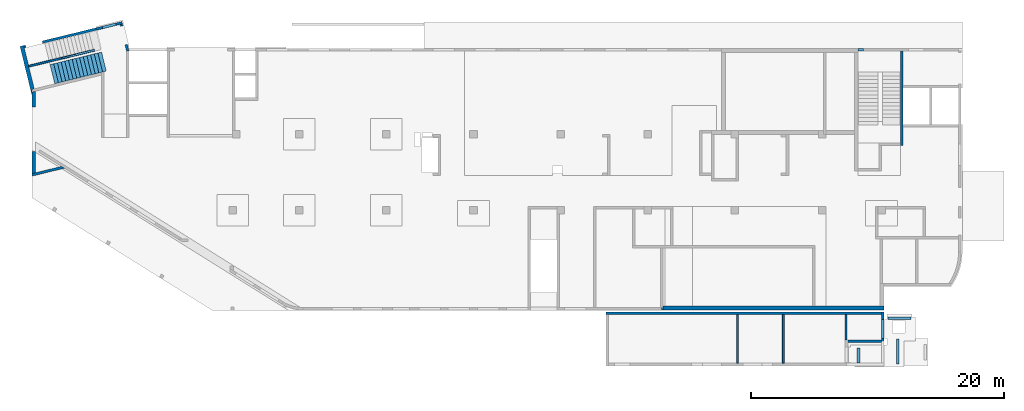
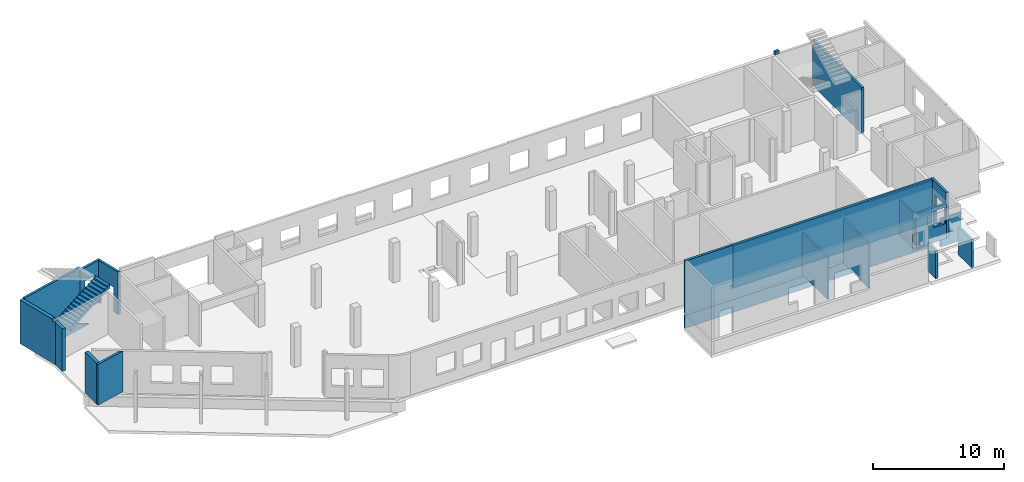
# One storey, part 4 of 8: 20 walls, 1 stair, 7 openings.
"""IFC4 building model written with IfcOpenShell, lengths in millimetres."""

from ifc_helpers import new_model, entity, si_unit, converted_unit, derived_unit, direction, frame, origin, place, context, subcontext, project, spatial, indexed_curve, outline, extrude, polygons, material, type_object, element, save


model = new_model("IFC4")

# Units and contexts
model_context = context("Model", 3, precision=0.01, world=origin(), true_north=direction((6.12303176911189e-17, 1.0)))
plan_context = context("Plan", 3, precision=0.01, world=origin(), true_north=direction((6.12303176911189e-17, 1.0)))
body_context = subcontext(model_context, "Body", "Model", "MODEL_VIEW")
ifc_project = project(units=[si_unit("LENGTHUNIT", "METRE", prefix="MILLI"), si_unit("AREAUNIT", "SQUARE_METRE"), si_unit("VOLUMEUNIT", "CUBIC_METRE"), converted_unit("PLANEANGLEUNIT", "DEGREE", entity("IfcRatioMeasure", 0.0174532925199433), si_unit("PLANEANGLEUNIT", "RADIAN"), dimensions=[0, 0, 0, 0, 0, 0, 0]), si_unit("MASSUNIT", "GRAM", prefix="KILO"), derived_unit("MASSDENSITYUNIT", [(si_unit("MASSUNIT", "GRAM", prefix="KILO"), 1), (si_unit("LENGTHUNIT", "METRE"), -3)]), derived_unit("MOMENTOFINERTIAUNIT", [(si_unit("LENGTHUNIT", "METRE"), 4)]), si_unit("TIMEUNIT", "SECOND"), si_unit("FREQUENCYUNIT", "HERTZ"), si_unit("THERMODYNAMICTEMPERATUREUNIT", "DEGREE_CELSIUS"), derived_unit("THERMALTRANSMITTANCEUNIT", [(si_unit("MASSUNIT", "GRAM", prefix="KILO"), 1), (si_unit("THERMODYNAMICTEMPERATUREUNIT", "KELVIN"), -1), (si_unit("TIMEUNIT", "SECOND"), -3)]), derived_unit("VOLUMETRICFLOWRATEUNIT", [(si_unit("LENGTHUNIT", "METRE"), 3), (si_unit("TIMEUNIT", "SECOND"), -1)]), derived_unit("MASSFLOWRATEUNIT", [(si_unit("MASSUNIT", "GRAM", prefix="KILO"), 1), (si_unit("TIMEUNIT", "SECOND"), -1)]), derived_unit("ROTATIONALFREQUENCYUNIT", [(si_unit("TIMEUNIT", "SECOND"), -1)]), si_unit("ELECTRICCURRENTUNIT", "AMPERE"), si_unit("ELECTRICVOLTAGEUNIT", "VOLT"), si_unit("POWERUNIT", "WATT"), si_unit("FORCEUNIT", "NEWTON", prefix="KILO"), si_unit("ILLUMINANCEUNIT", "LUX"), si_unit("LUMINOUSFLUXUNIT", "LUMEN"), si_unit("LUMINOUSINTENSITYUNIT", "CANDELA"), derived_unit("USERDEFINED", [(si_unit("MASSUNIT", "GRAM", prefix="KILO"), -1), (si_unit("LENGTHUNIT", "METRE"), -2), (si_unit("TIMEUNIT", "SECOND"), 3), (si_unit("LUMINOUSFLUXUNIT", "LUMEN"), 1)]), derived_unit("LINEARVELOCITYUNIT", [(si_unit("LENGTHUNIT", "METRE"), 1), (si_unit("TIMEUNIT", "SECOND"), -1)]), si_unit("PRESSUREUNIT", "PASCAL"), derived_unit("USERDEFINED", [(si_unit("LENGTHUNIT", "METRE"), -2), (si_unit("MASSUNIT", "GRAM", prefix="KILO"), 1), (si_unit("TIMEUNIT", "SECOND"), -2)]), derived_unit("LINEARFORCEUNIT", [(si_unit("MASSUNIT", "GRAM", prefix="KILO"), 1), (si_unit("LENGTHUNIT", "METRE"), 1), (si_unit("TIMEUNIT", "SECOND"), -2), (si_unit("LENGTHUNIT", "METRE"), -1)]), derived_unit("PLANARFORCEUNIT", [(si_unit("MASSUNIT", "GRAM", prefix="KILO"), 1), (si_unit("LENGTHUNIT", "METRE"), 1), (si_unit("TIMEUNIT", "SECOND"), -2), (si_unit("LENGTHUNIT", "METRE"), -2)])], contexts=[model_context, plan_context])

# Site, building, storey
site_placement = place(None, origin())
site = spatial("IfcSite", under=ifc_project, at=site_placement, CompositionType="ELEMENT")
building_placement = place(site_placement, origin())
building = spatial("IfcBuilding", under=site, at=building_placement, CompositionType="ELEMENT")
storey_placement = place(building_placement, origin())
storey = spatial("IfcBuildingStorey", under=building, at=storey_placement, CompositionType="ELEMENT", Elevation=0.0)

# Wall
ifc_material_1 = material()
wall_type_1 = type_object("IfcWallType", PredefinedType="STANDARD")
wall_1_placement = place(storey_placement, frame((68870.0002685547, 20299.9992263562, -250.0), z_axis=(0.0, 0.0, 1.0), x_axis=(0.0, -1.0, 0.0)))
element("IfcWall", 1, at=wall_1_placement, inside=storey, type_object=wall_type_1, material=ifc_material_1, PredefinedType="NOTDEFINED", context=body_context, shape_type="Tessellation", body=[
    polygons([(0.0, -99.9999999999859, 0.0), (100.000000000224, -99.9999999999943, 0.0), (7470.00000000022, -99.9999999999983, 0.0), (7470.00000000022, -99.9999999999983, 100.0), (7470.00000000022, -99.9999999999983, 4050.0), (7470.00000000022, -99.9999999999983, 4300.0), (2520.00000000074, -99.9999999999957, 4300.0), (0.0, -99.9999999999859, 4300.0), (0.0, -99.9999999999859, 4030.0), (2930.00000000025, -99.9999999999945, 4030.0), (2930.00000000025, -99.9999999999945, 3780.0), (0.0, -99.9999999999859, 3780.0), (7470.00000000021, 99.9999999999996, 0.0), (100.00000000022, 100.000000000004, 0.0), (-4.33146851719357e-12, 100.000000000003, 0.0), (-4.33146851719357e-12, 100.000000000003, 3780.0), (2930.00000000024, 99.9999999999947, 3780.0), (2930.00000000024, 99.9999999999947, 4030.0), (-4.33146851719357e-12, 100.000000000003, 4030.0), (-4.33146851719357e-12, 100.000000000003, 4300.0), (2520.00000000074, 100.000000000002, 4300.0), (2730.00000000074, 100.000000000003, 4300.0), (2930.00000000074, 100.000000000003, 4300.0), (7470.00000000021, 99.9999999999996, 4300.0)], [[[1, 2, 3, 4, 5, 6, 7, 8, 9, 10, 11, 12]], [[13, 14, 15, 16, 17, 18, 19, 20, 21, 22, 23, 24]], [[3, 2, 1, 15, 14, 13]], [[8, 7, 6, 24, 23, 22, 21, 20]], [[6, 5, 4, 3, 13, 24]], [[11, 17, 16, 12]], [[18, 10, 9, 19]], [[17, 11, 10, 18]], [[15, 1, 12, 16]], [[8, 20, 19, 9]]], closed=True),
])

# Wall, opening
wall_2_placement = place(storey_placement, frame((7154.27999642213, 22536.2793175299, -150.0), z_axis=(0.0, 0.0, 1.0), x_axis=(-0.971552058141473, -0.236826092990337, 0.0)))
wall_2 = element("IfcWall", 2, at=wall_2_placement, inside=storey, type_object=wall_type_1, material=ifc_material_1, PredefinedType="NOTDEFINED", context=body_context, shape_type="Tessellation", body=[
    polygons([(0.0, -99.9999999999989, 0.0), (2130.93783039304, -100.000000000003, 0.0), (2130.93783039304, -100.000000000003, 3950.0), (2129.99999999999, -100.000000000003, 3950.0), (2.16573425859679e-12, -99.9999999999989, 3950.0), (499.999999999999, -100.000000000319, 2700.0), (1600.0, -100.000000000324, 2700.0), (1600.0, -100.000000000324, 1000.00000000001), (499.999999999999, -100.000000000319, 1000.00000000001), (-1.08286712929839e-12, 99.9999999999989, 0.0), (-1.08286712929839e-12, 99.9999999999989, 3950.0), (199.999999999998, 99.9999999999989, 3950.0), (2130.93783039304, 99.9999999999989, 3950.0), (2130.93783039304, 99.9999999999989, 0.0), (199.999999999999, 99.9999999999989, 0.0), (1600.0, 100.000000000003, 2700.0), (499.999999999999, 99.9999999999989, 2700.0), (499.999999999999, 99.9999999999989, 1000.00000000001), (1600.0, 100.000000000003, 1000.00000000001)], [[[1, 2, 3, 4, 5], [6, 7, 8, 9]], [[10, 11, 12, 13, 14, 15], [16, 17, 18, 19]], [[2, 1, 10, 15, 14]], [[3, 2, 14, 13]], [[5, 4, 3, 13, 12, 11]], [[1, 5, 11, 10]], [[7, 6, 17, 16]], [[7, 16, 19, 8]], [[8, 19, 18, 9]], [[17, 6, 9, 18]]], closed=True),
])
opening_1_placement = place(wall_2_placement, frame((12287.9344363538, 20200.8483740857, 150.0), z_axis=(0.0, 0.0, 1.0), x_axis=(-0.971552058141473, 0.236826092990337, 0.0)))
element("IfcOpeningElement", 3, at=opening_1_placement, cuts=wall_2, PredefinedType="OPENING", context=body_context, shape_type="SweptSolid", body=[
    extrude(outline(indexed_curve([(-550.0, -849.999999999994), (550.0, -849.999999999994), (550.0, 849.999999999994), (-550.0, 849.999999999994), (-550.0, -849.999999999994)], self_intersect=False)), frame((6110.46772607433, 22384.7671257051, 1700.0), z_axis=(0.236826092990338, -0.971552058141473, 0.0), x_axis=(-0.971552058141473, -0.236826092990338, 0.0)), (0.0, 0.0, 1.0), 200.000000000964),
])

wall_3_placement = place(storey_placement, frame((7080.80739990702, 22415.4415024167, -150.0), z_axis=(0.0, 0.0, 1.0), x_axis=(0.236826092990336, -0.971552058141473, 0.0)))
wall_3 = element("IfcWall", 4, at=wall_3_placement, inside=storey, type_object=wall_type_1, material=ifc_material_1, PredefinedType="NOTDEFINED", context=body_context, shape_type="Tessellation", body=[
    polygons([(2180.28371765133, -100.000000000001, 3950.0), (8.66293703438714e-12, -100.0, 3950.0), (8.66293703438714e-12, -100.0, 0.0), (149.999999999996, -100.0, 0.0), (149.999999999996, -100.000000000001, 2279.99999999804), (1649.99999999999, -100.000000000001, 2279.99999999805), (1649.99999999999, -100.000000000001, 0.0), (2180.28371765133, -100.000000000001, 0.0), (4.33146851719357e-12, 99.9999999999989, 3950.0), (1995.90425351864, 99.9999999999984, 3950.0), (2201.76043829436, 99.9999999999978, 3950.0), (2204.30804833156, 99.9999999999978, 3950.0), (2204.30804833156, 99.9999999999978, 0.0), (2201.76043829436, 99.9999999999989, 0.0), (1995.90425351865, 99.9999999999995, 0.0), (1649.99999999999, 99.9999999999989, 0.0), (1649.99999999999, 99.9999999999978, 2279.99999999805), (149.999999999992, 99.9999999999978, 2279.99999999804), (149.999999999996, 99.9999999999989, 0.0), (4.33146851719357e-12, 99.9999999999989, 0.0)], [[[1, 2, 3, 4, 5, 6, 7, 8]], [[9, 10, 11, 12, 13, 14, 15, 16, 17, 18, 19, 20]], [[3, 20, 19, 4]], [[2, 1, 12, 11, 10, 9]], [[3, 2, 9, 20]], [[1, 8, 13, 12]], [[17, 6, 5, 18]], [[18, 5, 4, 19]], [[6, 17, 16, 7]], [[13, 8, 7, 16, 15, 14]]], closed=True),
])
opening_2_placement = place(wall_3_placement, frame((20100.8483740857, -12187.9344363538, 150.0), z_axis=(0.0, 0.0, 1.0), x_axis=(0.236826092990336, 0.971552058141473, 0.0)))
element("IfcOpeningElement", 5, at=opening_2_placement, cuts=wall_3, PredefinedType="OPENING", context=body_context, shape_type="SweptSolid", body=[
    extrude(outline(indexed_curve([(-1139.99999999902, -750.000000000002), (1139.99999999902, -750.000000000002), (1139.99999999902, 749.999999999998), (-1139.99999999902, 749.999999999998), (-1139.99999999902, -750.000000000002)], self_intersect=False)), frame((7099.64047197002, 21493.6794314913, 990.0), z_axis=(0.971552058141473, 0.236826092990336, 0.0), x_axis=(0.0, 0.0, -1.0)), (0.0, 0.0, 1.0), 400.000000001945),
])

# Wall
wall_4_placement = place(storey_placement, frame((-23.6823407443773, 10483.4730084749, 0.0), z_axis=(0.0, 0.0, 1.0), x_axis=(0.971552058141473, 0.236826092990339, 0.0)))
element("IfcWall", 6, at=wall_4_placement, inside=storey, type_object=wall_type_1, material=ifc_material_1, PredefinedType="NOTDEFINED", context=body_context, shape_type="Tessellation", body=[
    polygons([(0.0, -100.000000000001, 0.0), (2669.79789385161, -100.000000000001, 0.0), (2669.79789385161, -99.9999999999989, 3800.0), (0.0, -100.000000000001, 3800.0), (2474.61779994127, 99.9999999999968, 0.0), (357.536393121908, 99.9999999999989, 0.0), (48.7521159583308, 99.9999999999989, 0.0), (48.7521159583302, 99.9999999999989, 3800.0), (2474.61779994127, 99.9999999999989, 3800.0)], [[[1, 2, 3, 4]], [[5, 6, 7, 8, 9]], [[2, 1, 7, 6, 5]], [[2, 5, 9, 3]], [[7, 1, 4, 8]], [[4, 3, 9, 8]]], closed=True),
])

# Wall, opening
wall_5_placement = place(storey_placement, frame((5083.96296153225, 22031.6176367526, -150.0), z_axis=(0.0, 0.0, 1.0), x_axis=(-0.971552058141473, -0.236826092990335, 0.0)))
wall_5 = element("IfcWall", 7, at=wall_5_placement, inside=storey, type_object=wall_type_1, material=ifc_material_1, PredefinedType="NOTDEFINED", context=body_context, shape_type="Tessellation", body=[
    polygons([(5869.05423926975, -100.000000000003, 4200.0), (-1.08286712929839e-12, -100.000000000003, 4200.0), (-1.08286712929839e-12, -100.000000000003, 3950.0), (-1.08286712929839e-12, -100.000000000003, 0.0), (4369.05423926974, -100.000000000003, 0.0), (4369.05423926974, -100.000000000003, 1400.0), (5719.05423926973, -100.000000000003, 1400.0), (5719.05423926973, -100.000000000003, 0.0), (5869.05423926975, -100.000000000003, 0.0), (5869.05423926975, -100.000000000003, 4100.0), (-2.16573425859679e-12, 99.9999999999989, 4200.0), (5869.05423926975, 99.9999999999989, 4200.0), (5869.05423926975, 99.9999999999989, 0.0), (5719.05423926974, 99.9999999999946, 0.0), (5719.05423926974, 100.000000000311, 1400.0), (4369.05423926974, 100.000000000311, 1400.0), (4369.05423926974, 99.9999999999946, 0.0), (-2.16573425859679e-12, 99.9999999999989, 0.0), (-2.16573425859679e-12, 99.9999999999989, 3950.0)], [[[1, 2, 3, 4, 5, 6, 7, 8, 9, 10]], [[11, 12, 13, 14, 15, 16, 17, 18, 19]], [[4, 18, 17, 5]], [[2, 1, 12, 11]], [[4, 3, 2, 11, 19, 18]], [[15, 7, 6, 16]], [[16, 6, 5, 17]], [[7, 15, 14, 8]], [[1, 10, 9, 13, 12]], [[9, 8, 14, 13]]], closed=True),
])
opening_3_placement = place(wall_5_placement, origin())
element("IfcOpeningElement", 8, at=opening_3_placement, cuts=wall_5, PredefinedType="OPENING", context=body_context, shape_type="SweptSolid", body=[
    extrude(outline(indexed_curve([(-1089.99999999999, -675.0), (1089.99999999999, -675.0), (1089.99999999999, 675.0), (-1089.99999999999, 675.0), (-1089.99999999999, -675.0)], self_intersect=False)), frame((5044.05423926974, -200.0, 310.0), z_axis=(0.0, 1.0, 0.0), x_axis=(0.0, 0.0, -1.0)), (0.0, 0.0, 1.0), 300.000000000971),
])

# Walls
wall_6_placement = place(storey_placement, frame((65430.0002685547, 20399.9998657227, 3750.0)))
element("IfcWall", 9, at=wall_6_placement, inside=storey, type_object=wall_type_1, material=ifc_material_1, PredefinedType="NOTDEFINED", context=body_context, shape_type="SweptSolid", body=[
    extrude(outline(indexed_curve([(400.000000000048, 99.9999999999989), (0.0, 99.9999999999989), (0.0, -99.9999999999989), (400.000000000048, -99.9999999999989), (400.000000000048, 99.9999999999989)], self_intersect=False)), origin(), (0.0, 0.0, 1.0), 299.999999999999),
])
wall_7_placement = place(storey_placement, frame((45470.0036168839, -470.000875342555, -2100.0)))
element("IfcWall", 10, at=wall_7_placement, inside=storey, type_object=wall_type_1, material=ifc_material_1, PredefinedType="NOTDEFINED", context=body_context, shape_type="Tessellation", body=[
    polygons([(0.0, -100.0, 0.0), (199.999999999998, -100.0, 0.0), (21799.9966516707, -100.0, 0.0), (21799.9966516707, -100.0, 6280.0), (199.999999999998, -100.0, 6280.0), (0.0, -100.0, 6280.0), (0.0, -100.0, 1400.0), (199.999999999998, -100.0, 1400.0), (10325.0000000001, -100.0, 1400.0), (10475.0000000001, -100.0, 1400.0), (13955.0000000001, -100.0, 1400.0), (13955.0000000001, -100.0, 1200.0), (199.999999999998, -100.0, 1200.0), (0.0, -100.0, 1200.0), (21799.9966516707, 100.0, 0.0), (0.0, 100.0, 0.0), (0.0, 100.0, 1200.0), (13955.0000000001, 99.9999999999986, 1200.0), (13955.0000000001, 99.9999999999986, 1400.0), (0.0, 100.0, 1400.0), (0.0, 100.0, 6280.0), (21799.9966516707, 100.0, 6280.0), (21799.9966516707, 100.0, 2100.0)], [[[1, 2, 3, 4, 5, 6, 7, 8, 9, 10, 11, 12, 13, 14]], [[15, 16, 17, 18, 19, 20, 21, 22, 23]], [[3, 2, 1, 16, 15]], [[6, 5, 4, 22, 21]], [[6, 21, 20, 7]], [[4, 3, 15, 23, 22]], [[12, 18, 17, 14, 13]], [[19, 11, 10, 9, 8, 7, 20]], [[18, 12, 11, 19]], [[16, 1, 14, 17]]], closed=True),
])

# Wall, opening
wall_8_placement = place(storey_placement, frame((67370.0002685546, -370.000875342555, 0.0), z_axis=(0.0, 0.0, 1.0), x_axis=(0.0, -1.0, 0.0)))
wall_8 = element("IfcWall", 11, at=wall_8_placement, inside=storey, type_object=wall_type_1, material=ifc_material_1, PredefinedType="NOTDEFINED", context=body_context, shape_type="Tessellation", body=[
    polygons([(0.0, -100.000000000004, 0.0), (2199.99992981406, -99.9999999999998, 0.0), (2399.99992981406, -99.9999999999916, 0.0), (2399.99992981406, -99.9999999999916, 3230.0), (2299.99992981406, -99.9999999999914, 3230.0), (2299.99992981406, -99.9999999999914, 4180.0), (200.0, -99.9999999999958, 4180.0), (0.0, -100.000000000004, 4180.0), (600.000055868205, -100.000000000005, 2929.99999999804), (2100.00005586821, -99.999999999991, 2929.99999999804), (2100.00005586821, -99.999999999991, 530.0), (600.000055868206, -100.000000000005, 530.0), (2399.99992981406, 100.000000000006, 0.0), (4.06075173486897e-13, 100.000000000002, 0.0), (4.06075173486897e-13, 100.000000000002, 4180.0), (2299.99992981406, 100.000000000006, 4180.0), (2299.99992981406, 100.000000000006, 3230.0), (2399.99992981406, 100.000000000006, 3230.0), (2100.00005586821, 99.9999999999982, 2929.99999999804), (600.000055868206, 100.000000000001, 2929.99999999804), (600.000055868206, 100.000000000001, 530.0), (2100.00005586821, 99.9999999999982, 530.0)], [[[1, 2, 3, 4, 5, 6, 7, 8], [9, 10, 11, 12]], [[13, 14, 15, 16, 17, 18], [19, 20, 21, 22]], [[3, 2, 1, 14, 13]], [[8, 7, 6, 16, 15]], [[1, 8, 15, 14]], [[16, 6, 5, 17]], [[17, 5, 4, 18]], [[3, 13, 18, 4]], [[9, 20, 19, 10]], [[10, 19, 22, 11]], [[11, 22, 21, 12]], [[20, 9, 12, 21]]], closed=True),
])
opening_4_placement = place(wall_8_placement, frame((-370.000875342555, -67370.0002685546, 0.0), z_axis=(0.0, 0.0, 1.0), x_axis=(0.0, 1.0, 0.0)))
element("IfcOpeningElement", 12, at=opening_4_placement, cuts=wall_8, PredefinedType="OPENING", context=body_context, shape_type="SweptSolid", body=[
    extrude(outline(indexed_curve([(-750.0, -1199.99999999902), (750.0, -1199.99999999902), (750.0, 1199.99999999902), (-750.0, 1199.99999999902), (-750.0, -1199.99999999902)], self_intersect=False)), frame((67170.0002685527, -1720.00093121076, 1730.0), z_axis=(1.0, 0.0, 0.0), x_axis=(0.0, -1.0, 0.0)), (0.0, 0.0, 1.0), 400.000000001936),
])

wall_9_placement = place(storey_placement, frame((64600.003616884, -2670.00080515661, 0.0)))
wall_9 = element("IfcWall", 13, at=wall_9_placement, inside=storey, type_object=wall_type_1, material=ifc_material_1, PredefinedType="NOTDEFINED", context=body_context, shape_type="Tessellation", body=[
    polygons([(2.20736734168918e-13, -100.0, 0.0), (2669.99665167067, -100.000000000001, 0.0), (2669.99665167067, -100.000000000001, 3230.0), (2.20736734168918e-13, -100.0, 3230.0), (2569.99665167068, -100.0, 2930.0), (2569.99665167068, -100.0, 1400.0), (1519.99665167067, -100.0, 1400.0), (1519.99665167067, -100.0, 2930.0), (-4.20683568093687e-13, 100.0, 0.0), (-4.20683568093687e-13, 100.0, 330.0), (-4.20683568093687e-13, 100.0, 530.0), (-4.20683568093687e-13, 100.0, 3230.0), (2669.99665167065, 99.9999999999995, 3230.0), (2669.99665167065, 99.9999999999995, 0.0), (2569.99665167068, 100.0, 2930.0), (1519.99665167067, 100.0, 2930.0), (1519.99665167067, 100.0, 1400.0), (2569.99665167068, 100.0, 1400.0), (2669.99665167067, -1.62430069394759e-12, 3230.0)], [[[1, 2, 3, 4], [5, 6, 7, 8]], [[9, 10, 11, 12, 13, 14], [15, 16, 17, 18]], [[1, 4, 12, 11, 10, 9]], [[3, 2, 14, 13, 19]], [[4, 3, 19, 13, 12]], [[2, 1, 9, 14]], [[6, 5, 15, 18]], [[7, 6, 18, 17]], [[8, 7, 17, 16]], [[5, 8, 16, 15]]], closed=True),
])
opening_5_placement = place(wall_9_placement, origin())
element("IfcOpeningElement", 14, at=opening_5_placement, cuts=wall_9, PredefinedType="OPENING", context=body_context, shape_type="SweptSolid", body=[
    extrude(outline(indexed_curve([(-525.000000000002, -765.0), (525.000000000002, -765.0), (525.000000000002, 765.0), (-525.000000000002, 765.0), (-525.000000000002, -765.0)], self_intersect=False)), frame((2044.99665167068, 100.0, 2165.0), z_axis=(0.0, -1.0, 0.0), x_axis=(-1.0, 0.0, 0.0)), (0.0, 0.0, 1.0), 200.0),
])

# Walls
wall_10_placement = place(storey_placement, frame((65450.0036200273, -4420.00087534259, -2100.0), z_axis=(0.0, 0.0, 1.0), x_axis=(0.0, 1.0, 0.0)))
element("IfcWall", 15, at=wall_10_placement, inside=storey, type_object=wall_type_1, material=ifc_material_1, PredefinedType="NOTDEFINED", context=body_context, shape_type="Tessellation", body=[
    polygons([(0.0, -99.9999999999946, 0.0), (1225.00005833431, -99.9999999999946, 0.0), (1225.00005833431, -99.9999999999946, 2590.0), (0.0, -99.9999999999946, 2590.0), (5.41433564649196e-13, 99.9999999999946, 0.0), (5.41433564649196e-13, 99.9999999999946, 2590.0), (1225.00005833431, 99.9999999999946, 2590.0), (1225.00005833431, 99.9999999999946, 0.0)], [[[1, 2, 3, 4]], [[5, 6, 7, 8]], [[2, 1, 5, 8]], [[3, 2, 8, 7]], [[1, 4, 6, 5]], [[4, 3, 7, 6]]], closed=True),
])
wall_11_placement = place(storey_placement, frame((68545.0077758905, -4495.00080359939, -2100.0), z_axis=(0.0, 0.0, 1.0), x_axis=(0.0, 1.0, 0.0)))
element("IfcWall", 16, at=wall_11_placement, inside=storey, type_object=wall_type_1, material=ifc_material_1, PredefinedType="NOTDEFINED", context=body_context, shape_type="Tessellation", body=[
    polygons([(0.0, -99.9999999999946, 0.0), (1999.9999865911, -99.9999999999946, 0.0), (1999.9999865911, -99.9999999999946, 2590.0), (0.0, -99.9999999999946, 2590.0), (0.0, 99.9999999999946, 0.0), (0.0, 99.9999999999946, 2590.0), (1999.9999865911, 99.9999999999946, 2590.0), (1999.9999865911, 99.9999999999946, 0.0)], [[[1, 2, 3, 4]], [[5, 6, 7, 8]], [[2, 1, 5, 8]], [[3, 2, 8, 7]], [[1, 4, 6, 5]], [[4, 3, 7, 6]]], closed=True),
])
wall_12_placement = place(storey_placement, frame((67795.0036168839, -855.000773644068, -2100.0)))
element("IfcWall", 17, at=wall_12_placement, inside=storey, type_object=wall_type_1, material=ifc_material_1, PredefinedType="NOTDEFINED", context=body_context, shape_type="Tessellation", body=[
    polygons([(3.08805379778116e-12, -100.0, 0.0), (1800.00000000001, -100.0, 0.0), (1800.00000000001, -100.0, 2590.0), (3.08805379778116e-12, -100.0, 2590.0), (2.44134148445018e-12, 100.0, 0.0), (2.44134151673763e-12, 99.9999900148955, 2590.0), (1800.00000000001, 100.0, 2590.0), (1800.00000000001, 100.0, 0.0)], [[[1, 2, 3, 4]], [[5, 6, 7, 8]], [[2, 1, 5, 8]], [[3, 2, 8, 7]], [[1, 4, 6, 5]], [[4, 3, 7, 6]]], closed=True),
])
wall_type_2 = type_object("IfcWallType", PredefinedType="STANDARD")
wall_13_placement = place(storey_placement, frame((49870.0002685546, -50.0007736438373, -150.0)))
element("IfcWall", 18, at=wall_13_placement, inside=storey, type_object=wall_type_2, material=ifc_material_1, PredefinedType="NOTDEFINED", context=body_context, shape_type="Tessellation", body=[
    polygons([(6.46066962494362e-13, -150.0, 0.0), (17600.0, -150.0, 0.0), (17600.0, -150.0, 3900.0), (11950.0, -149.999999999981, 3900.0), (11950.0, -150.0, 3950.0), (99.9999999999952, -150.0, 3950.0), (99.9999999999952, -150.0, 150.0), (6.46066962494362e-13, -150.0, 150.0), (17600.0, 150.0, 0.0), (17300.0, 150.0, 0.0), (12150.0, 150.0, 0.0), (11950.0, 150.0, 0.0), (-3.23029732568751e-13, 150.0, 0.0), (-3.23029732568751e-13, 150.0, 150.0), (99.9999999999943, 150.0, 150.0), (99.9999999999943, 150.0, 3950.0), (3400.00000000001, 150.0, 3950.0), (3600.0, 150.0, 3950.0), (7775.0, 150.0, 3950.0), (7974.99999999999, 150.0, 3950.0), (11950.0, 150.0, 3950.0), (11950.0, 150.000000000001, 3900.0), (12150.0, 150.0, 3900.0), (12850.0, 150.0, 3900.0), (13050.0, 150.0, 3900.0), (17000.0, 150.0, 3900.0), (17200.0, 150.0, 3900.0), (17300.0, 150.0, 3900.0), (17600.0, 150.0, 3900.0), (2.49911895314559e-18, 50.0, 0.0), (99.9999999999946, 50.0, 3950.0), (2.49911895314559e-18, 50.0, 150.0), (99.9999999999946, 50.0, 150.0)], [[[1, 2, 3, 4, 5, 6, 7, 8]], [[9, 10, 11, 12, 13, 14, 15, 16, 17, 18, 19, 20, 21, 22, 23, 24, 25, 26, 27, 28, 29]], [[2, 1, 30, 13, 12, 11, 10, 9]], [[16, 31, 6, 5, 21, 20, 19, 18, 17]], [[2, 9, 29, 3]], [[13, 30, 1, 8, 32, 14]], [[6, 31, 16, 15, 33, 7]], [[22, 4, 3, 29, 28, 27, 26, 25, 24, 23]], [[4, 22, 21, 5]], [[15, 14, 32, 8, 7, 33]]], closed=True),
])

# Wall, opening
wall_14_placement = place(storey_placement, frame((-787.544181994472, 20703.3037435836, -150.0), z_axis=(0.0, 0.0, 1.0), x_axis=(0.236826092990336, -0.971552058141473, 0.0)))
wall_14 = element("IfcWall", 19, at=wall_14_placement, inside=storey, type_object=wall_type_2, material=ifc_material_1, PredefinedType="NOTDEFINED", context=body_context, shape_type="Tessellation", body=[
    polygons([(0.0, -150.000000000002, 0.0), (1620.0, -150.000000000001, 0.0), (3940.77040872537, -150.000000000001, 0.0), (3940.77040872537, -150.000000000002, 3950.0), (3540.00000000001, -150.0, 3950.0), (3540.00000000001, -150.000000000001, 4100.0), (0.0, -150.000000000002, 4100.0), (3540.00000000002, 149.999999999999, 4100.0), (3540.00000000001, 149.999999999999, 2220.0), (3540.00000000001, 149.999999999999, 2020.0), (3540.0, 149.999999999999, 0.0), (1770.0, 149.999999999999, 0.0), (1620.0, 149.999999999999, 0.0), (199.999999999998, 149.999999999999, 0.0), (4.33146851719357e-12, 149.999999999999, 0.0), (4.33146851719357e-12, 149.999999999999, 4100.0), (3540.00000000001, -52.307972805769, 0.0), (3740.00000000001, -101.060088764098, 0.0), (3540.00000000001, -52.3079728057685, 3950.0), (3740.00000000001, -101.060088764098, 3950.0)], [[[1, 2, 3, 4, 5, 6, 7]], [[8, 9, 10, 11, 12, 13, 14, 15, 16]], [[3, 2, 1, 15, 14, 13, 12, 11, 17, 18]], [[16, 7, 6, 8]], [[17, 11, 10, 9, 8, 6, 5, 19]], [[3, 18, 17, 19, 20, 4]], [[1, 7, 16, 15]], [[19, 5, 4, 20]]], closed=True),
])
opening_6_placement = place(wall_14_placement, origin())
element("IfcOpeningElement", 20, at=opening_6_placement, cuts=wall_14, PredefinedType="OPENING", context=body_context, shape_type="SweptSolid", body=[
    extrude(outline(indexed_curve([(-150.000000000483, -1089.99999999999), (150.000000000484, -1089.99999999999), (150.000000000478, 1089.99999999999), (-150.000000000484, 1089.99999999999), (-150.000000000483, -1089.99999999999)], self_intersect=False)), frame((50.0, 300.0, 310.0), z_axis=(0.0, 1.0, 0.0), x_axis=(-1.0, 0.0, 0.0)), (0.0, 0.0, 1.0), 1350.0),
])

# Walls
wall_15_placement = place(storey_placement, frame((150.000268554657, 10592.1739874364, 0.0), z_axis=(0.0, 0.0, 1.0), x_axis=(0.0, 1.0, 0.0)))
element("IfcWall", 21, at=wall_15_placement, inside=storey, type_object=wall_type_2, material=ifc_material_1, PredefinedType="NOTDEFINED", context=body_context, shape_type="Tessellation", body=[
    polygons([(73.1281739374965, -150.0, 0.0), (1742.70851127241, -150.0, 0.0), (1742.70851127241, -150.0, 3800.0), (73.1281739374965, -150.0, 3800.0), (1742.70851127241, 150.0, 0.0), (0.0, 150.0, 0.0), (0.0, 150.0, 3800.0), (1742.70851127241, 150.0, 3800.0), (1742.70851127241, 149.788393424096, 0.0), (1742.70851127241, 149.788393424096, 3800.0)], [[[1, 2, 3, 4]], [[5, 6, 7, 8]], [[2, 1, 6, 5, 9]], [[3, 2, 9, 5, 8, 10]], [[6, 1, 4, 7]], [[4, 3, 10, 8, 7]]], closed=True),
])
wall_16_placement = place(storey_placement, frame((150.000268554665, 15852.4563734385, -150.0), z_axis=(0.0, 0.0, 1.0), x_axis=(0.0, 1.0, 0.0)))
element("IfcWall", 22, at=wall_16_placement, inside=storey, type_object=wall_type_2, material=ifc_material_1, PredefinedType="NOTDEFINED", context=body_context, shape_type="Tessellation", body=[
    polygons([(2.16573425859679e-12, -150.0, 0.0), (1266.43718065428, -150.0, 0.0), (1266.43718065428, -150.0, 3950.0), (2.16573425859679e-12, -150.0, 3950.0), (1193.30900671678, 150.0, 0.0), (986.659854936454, 150.0, 0.0), (2.16573425859679e-12, 150.0, 0.0), (2.16573425859679e-12, 150.0, 3950.0), (986.659854936441, 150.0, 3950.0), (1193.30900671678, 150.0, 3950.0)], [[[1, 2, 3, 4]], [[5, 6, 7, 8, 9, 10]], [[2, 1, 7, 6, 5]], [[7, 1, 4, 8]], [[2, 5, 10, 3]], [[4, 3, 10, 9, 8]]], closed=True),
])
wall_type_3 = type_object("IfcWallType", PredefinedType="STANDARD")
wall_17_placement = place(storey_placement, frame((-240.391145654632, 19092.0469189824, -150.0), z_axis=(0.0, 0.0, 1.0), x_axis=(0.971552058141474, 0.236826092990335, 0.0)))
element("IfcWall", 23, at=wall_17_placement, inside=storey, type_object=wall_type_3, material=ifc_material_1, PredefinedType="NOTDEFINED", context=body_context, shape_type="Tessellation", body=[
    polygons([(1.62430069394759e-12, -74.9999999999981, 0.0), (5362.78640450009, -75.0000000000003, 1.86117787848161e-13), (1322.78640450004, -75.0000000000024, 2020.0), (0.0, -75.0000000000024, 2020.0), (1.62430069394759e-12, 75.0000000000024, 0.0), (0.0, 75.0000000000003, 2020.0), (1322.78640450005, 75.0000000000003, 2020.0), (5362.78640450009, 75.0000000000003, 1.86117787848161e-13)], [[[1, 2, 3, 4]], [[5, 6, 7, 8]], [[1, 4, 6, 5]], [[2, 1, 5, 8]], [[3, 2, 8, 7]], [[4, 3, 7, 6]]], closed=True),
])
wall_18_placement = place(storey_placement, frame((55870.003616884, -4420.00087534259, -700.0), z_axis=(0.0, 0.0, 1.0), x_axis=(0.0, 1.0, 0.0)))
element("IfcWall", 24, at=wall_18_placement, inside=storey, type_object=wall_type_3, material=ifc_material_1, PredefinedType="NOTDEFINED", context=body_context, shape_type="Tessellation", body=[
    polygons([(0.0, -75.0000000000016, 0.0), (3850.00000000003, -75.0000000000016, 0.0), (3850.00000000003, -75.0000000000016, 3930.0), (0.0, -75.0000000000016, 3930.0), (0.0, 74.999999999999, 0.0), (0.0, 74.999999999999, 3930.0), (3850.00000000003, 74.999999999999, 3930.0), (3850.00000000003, 74.999999999999, 0.0)], [[[1, 2, 3, 4]], [[5, 6, 7, 8]], [[2, 1, 5, 8]], [[3, 2, 8, 7]], [[1, 4, 6, 5]], [[4, 3, 7, 6]]], closed=True),
])
wall_19_placement = place(storey_placement, frame((59500.0036168839, -4420.00087534259, -900.0), z_axis=(0.0, 0.0, 1.0), x_axis=(0.0, 1.0, 0.0)))
element("IfcWall", 25, at=wall_19_placement, inside=storey, type_object=wall_type_3, material=ifc_material_1, PredefinedType="NOTDEFINED", context=body_context, shape_type="Tessellation", body=[
    polygons([(5.41433564649196e-13, -75.0000000000016, 0.0), (3850.00000000003, -75.0000000000016, 0.0), (3850.00000000003, -75.0000000000016, 4130.0), (5.41433564649196e-13, -75.0000000000016, 4130.0), (5.41433564649196e-13, -75.0000000000016, 1430.0), (5.41433564649196e-13, -75.0000000000016, 1230.0), (0.0, 74.999999999999, 0.0), (0.0, 74.999999999999, 200.0), (0.0, 74.999999999999, 4130.0), (3850.00000000003, 74.999999999999, 4130.0), (3850.00000000003, 74.999999999999, 200.0), (3850.00000000003, 74.999999999999, 0.0)], [[[1, 2, 3, 4, 5, 6]], [[7, 8, 9, 10, 11, 12]], [[2, 1, 7, 12]], [[3, 2, 12, 11, 10]], [[1, 6, 5, 4, 9, 8, 7]], [[4, 3, 10, 9]]], closed=True),
])

# Wall, opening
wall_20_placement = place(storey_placement, frame((64475.003616884, -570.000875342555, 0.0), z_axis=(0.0, 0.0, 1.0), x_axis=(0.0, -1.0, 0.0)))
wall_20 = element("IfcWall", 26, at=wall_20_placement, inside=storey, type_object=wall_type_3, material=ifc_material_1, PredefinedType="NOTDEFINED", context=body_context, shape_type="Tessellation", body=[
    polygons([(0.0, -75.0000000000003, 0.0), (1999.99992981405, -75.0000000000003, 0.0), (1999.99992981405, -75.0000000000003, 330.0), (0.0, -75.0000000000003, 330.0), (1999.99992981405, 75.0000000000003, 0.0), (0.0, 75.0000000000003, 0.0), (0.0, 75.0000000000003, 330.0), (1999.99992981405, 75.0000000000003, 330.0)], [[[1, 2, 3, 4]], [[5, 6, 7, 8]], [[2, 1, 6, 5]], [[2, 5, 8, 3]], [[6, 1, 4, 7]], [[4, 3, 8, 7]]], closed=True),
    polygons([(1999.99992981405, -75.0000000000003, 530.0), (0.0, -75.0000000000003, 530.0), (0.0, 75.0000000000003, 530.0), (1999.99992981405, 75.0000000000003, 530.0), (0.0, -75.0000000000003, 3230.0), (1999.99992981405, -75.0000000000003, 3230.0), (1999.99992981405, 75.0000000000003, 3230.0), (0.0, 75.0000000000003, 3230.0)], [[[1, 2, 3, 4]], [[5, 6, 7, 8]], [[5, 8, 3, 2]], [[7, 6, 1, 4]], [[8, 7, 4, 3]], [[6, 5, 2, 1]]], closed=True),
])
opening_7_placement = place(storey_placement, frame((64475.003616884, -570.000875342555, 0.0), z_axis=(0.0, 0.0, 1.0), x_axis=(0.0, -1.0, 0.0)))
element("IfcOpeningElement", 27, at=opening_7_placement, cuts=wall_20, PredefinedType="OPENING", context=body_context, shape_type="SweptSolid", body=[
    extrude(outline(indexed_curve([(-999.999964907026, -75.0000000000003), (999.999964907026, -75.0000000000003), (999.999964907026, 75.0000000000003), (-999.999964907026, 75.0000000000003), (-999.999964907026, -75.0000000000003)], self_intersect=False)), frame((999.999964907026, 0.0, 330.0)), (0.0, 0.0, 1.0), 200.0),
])

# Stair
ifc_material_2 = material()
stair_type = type_object("IfcStairType", PredefinedType="HALF_TURN_STAIR")
stair_placement = place(storey_placement, origin())
element("IfcStair", 28, at=stair_placement, inside=storey, type_object=stair_type, material=ifc_material_2, PredefinedType="HALF_TURN_STAIR", context=body_context, shape_type="SweptSolid", body=[
    extrude(outline(indexed_curve([(-2092.32535407269, -930.0), (-2092.32535407269, -1280.0), (-2045.11175857273, -1280.0), (1814.88824142724, 649.999999999966), (2107.66671559009, 649.999999999966), (2107.6667155901, 1020.0), (1807.67464592736, 1020.0), (1807.67464592736, 870.000000000003), (1507.67464592735, 870.000000000003), (1507.67464592735, 720.000000000003), (1207.67464592735, 720.000000000003), (1207.67464592735, 570.000000000003), (907.674645927345, 570.000000000002), (907.674645927344, 420.000000000002), (607.67464592734, 420.000000000002), (607.67464592734, 270.000000000002), (307.674645927336, 270.000000000002), (307.674645927335, 120.000000000002), (7.67464592733123, 120.000000000001), (7.67464592733001, -29.9999999999987), (-292.325354072673, -29.9999999999989), (-292.325354072673, -179.999999999999), (-592.325354072676, -179.999999999999), (-592.325354072678, -329.999999999999), (-892.325354072679, -329.999999999999), (-892.32535407268, -479.999999999999), (-1192.32535407268, -480.0), (-1192.32535407268, -630.0), (-1492.32535407268, -630.0), (-1492.32535407268, -780.0), (-1792.32535407269, -780.0), (-1792.32535407269, -930.0), (-2092.32535407269, -930.0)], self_intersect=False)), frame((3847.11141519991, 18209.9812270377, 3150.0), z_axis=(0.236826092990333, -0.971552058141474, 0.0), x_axis=(0.971552058141474, 0.236826092990333, 0.0)), (0.0, 0.0, -1.0), 1550.0),
])

save(model, "model.ifc")
